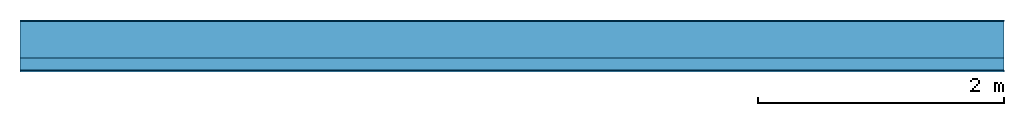
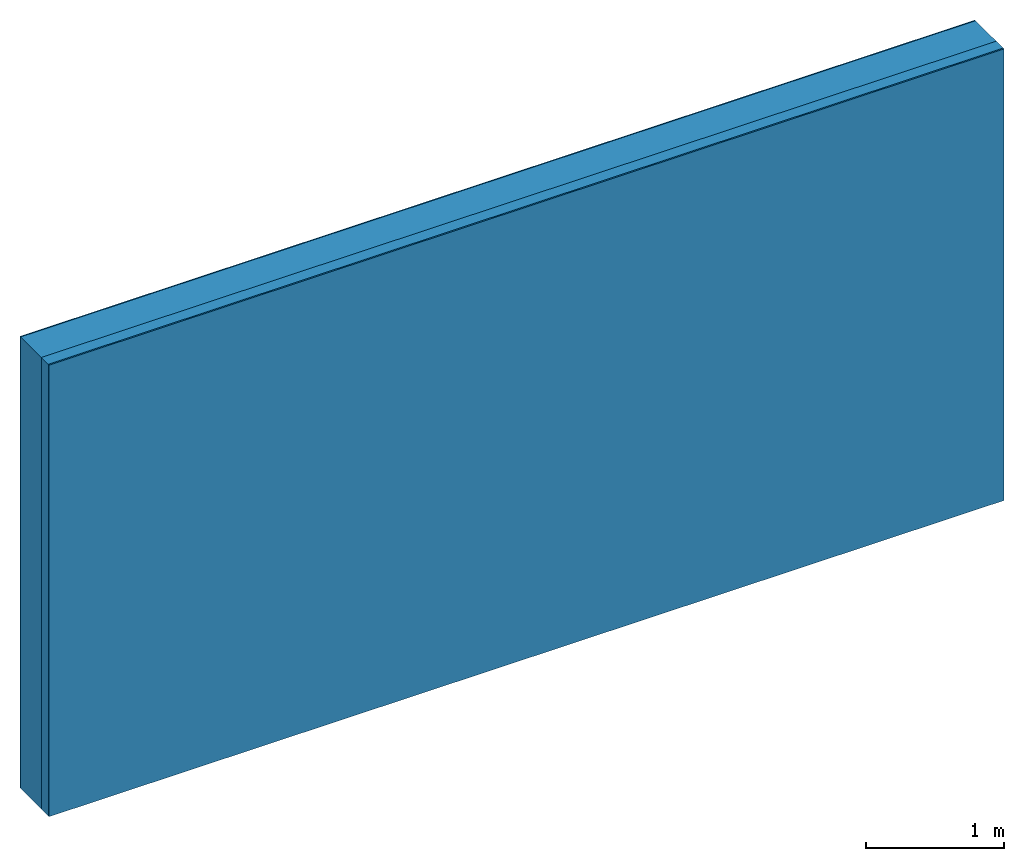
# One storey: 3 plates, 1 member, 1 element without a shape of its own.
"""IFC4 building model written with IfcOpenShell, lengths in metres."""

from ifc_helpers import new_model, si_unit, derived_unit, direction, frame, frame_2d, origin, origin_with_axes, place, context, project, spatial, rectangle, extrude, material, layer, layer_set, type_object, element, aggregate, save


model = new_model("IFC4")

# Units and contexts
plan_context = context("Plan", 3, precision=1e-05, world=origin(), true_north=direction((0.0, 1.0)))
model_context = context("Model", 3, precision=1e-05, world=origin(), true_north=direction((0.0, 1.0)))
ifc_project = project(units=[si_unit("LENGTHUNIT", "METRE"), derived_unit("SOUNDPRESSUREUNIT", [(si_unit("PRESSUREUNIT", "PASCAL", prefix="MICRO"), 0)]), si_unit("ENERGYUNIT", "JOULE", prefix="MEGA"), si_unit("MASSUNIT", "GRAM", prefix="KILO"), derived_unit("THERMALTRANSMITTANCEUNIT", [(si_unit("POWERUNIT", "WATT"), 1), (si_unit("AREAUNIT", "SQUARE_METRE"), -1), (si_unit("THERMODYNAMICTEMPERATUREUNIT", "KELVIN"), -1)]), derived_unit("AREADENSITYUNIT", [(si_unit("MASSUNIT", "GRAM", prefix="KILO"), 1), (si_unit("AREAUNIT", "SQUARE_METRE"), -1)]), derived_unit("USERDEFINED", [(si_unit("ENERGYUNIT", "JOULE", prefix="MEGA"), 1), (si_unit("AREAUNIT", "SQUARE_METRE"), -1)])], contexts=[plan_context, model_context])

# Site, building, storey
site = spatial("IfcSite", under=ifc_project)
building_placement = place(None, origin())
building = spatial("IfcBuilding", under=site, at=building_placement)
storey_placement = place(building_placement, origin())
storey = spatial("IfcBuildingStorey", under=building, at=storey_placement)

# Wall, member, plates
ifc_material_1 = material(Category="04.011")
ifc_layer_1 = layer(ifc_material_1, 0.01, Name="Surface 1")
ifc_material_2 = material(Name="Mineral wool", Category="10.008")
ifc_layer_2 = layer(ifc_material_2, 0.3, Name="outside 1st layer")
ifc_material_3 = material(Name="of the art")
ifc_layer_3 = layer(ifc_material_3, 0.0, Name="Bond")
ifc_layer_4 = layer(None, 0.1, Name="Support")
ifc_layer_5 = layer(ifc_material_3, 0.0, Name="Bond")
ifc_material_4 = material(Name="Plasterboard type A", Category="03.008")
ifc_layer_6 = layer(ifc_material_4, 0.0125, Name="1st layer")
ifc_material_5 = material(Name="joints", Category="04.017")
ifc_layer_7 = layer(ifc_material_5, 0.0, Name="Surface")
ifc_layer_set = layer_set([ifc_layer_1, ifc_layer_2, ifc_layer_3, ifc_layer_4, ifc_layer_5, ifc_layer_6, ifc_layer_7])
wall_type = type_object("IfcWallType", Name="D1028", PredefinedType="NOTDEFINED", material=ifc_layer_set)
wall_placement = place(None, frame((0.0, 0.0, 0.0), z_axis=(0.0, -1.0, 0.0), x_axis=(1.0, 0.0, 0.0)))
wall = element("IfcWall", 1, at=wall_placement, inside=storey, type_object=wall_type, material=ifc_layer_set, Name="Wall #1")
ifc_material_6 = material(Name="Solid timber panel")
member_placement = place(wall_placement, origin())
member = element("IfcMember", 2, at=member_placement, material=ifc_material_6, Name="Support", context=plan_context, shape_type="SweptSolid", body=[
    extrude(rectangle(XDim=1.0, YDim=0.1, at=frame_2d((0.5, 0.05), x_axis=(1.0, 0.0))), frame((0.0, 4.0, 0.31), z_axis=(0.0, -1.0, 0.0), x_axis=(1.0, 0.0, 0.0)), (0.0, 0.0, 1.0), 4.0),
    extrude(rectangle(XDim=1.0, YDim=0.1, at=frame_2d((0.5, 0.05), x_axis=(1.0, 0.0))), frame((1.0, 4.0, 0.31), z_axis=(0.0, -1.0, 0.0), x_axis=(1.0, 0.0, 0.0)), (0.0, 0.0, 1.0), 4.0),
    extrude(rectangle(XDim=1.0, YDim=0.1, at=frame_2d((0.5, 0.05), x_axis=(1.0, 0.0))), frame((2.0, 4.0, 0.31), z_axis=(0.0, -1.0, 0.0), x_axis=(1.0, 0.0, 0.0)), (0.0, 0.0, 1.0), 4.0),
    extrude(rectangle(XDim=1.0, YDim=0.1, at=frame_2d((0.5, 0.05), x_axis=(1.0, 0.0))), frame((3.0, 4.0, 0.31), z_axis=(0.0, -1.0, 0.0), x_axis=(1.0, 0.0, 0.0)), (0.0, 0.0, 1.0), 4.0),
    extrude(rectangle(XDim=1.0, YDim=0.1, at=frame_2d((0.5, 0.05), x_axis=(1.0, 0.0))), frame((4.0, 4.0, 0.31), z_axis=(0.0, -1.0, 0.0), x_axis=(1.0, 0.0, 0.0)), (0.0, 0.0, 1.0), 4.0),
    extrude(rectangle(XDim=1.0, YDim=0.1, at=frame_2d((0.5, 0.05), x_axis=(1.0, 0.0))), frame((5.0, 4.0, 0.31), z_axis=(0.0, -1.0, 0.0), x_axis=(1.0, 0.0, 0.0)), (0.0, 0.0, 1.0), 4.0),
    extrude(rectangle(XDim=1.0, YDim=0.1, at=frame_2d((0.5, 0.05), x_axis=(1.0, 0.0))), frame((6.0, 4.0, 0.31), z_axis=(0.0, -1.0, 0.0), x_axis=(1.0, 0.0, 0.0)), (0.0, 0.0, 1.0), 4.0),
    extrude(rectangle(XDim=1.0, YDim=0.1, at=frame_2d((0.5, 0.05), x_axis=(1.0, 0.0))), frame((7.0, 4.0, 0.31), z_axis=(0.0, -1.0, 0.0), x_axis=(1.0, 0.0, 0.0)), (0.0, 0.0, 1.0), 4.0),
])
plate_1_placement = place(wall_placement, origin())
plate_1 = element("IfcPlate", 3, at=plate_1_placement, material=ifc_material_1, Name="Surface 1", context=plan_context, shape_type="SweptSolid", body=[
    extrude(rectangle(XDim=8.0, YDim=4.0, at=frame_2d((4.0, 2.0), x_axis=(1.0, 0.0))), origin_with_axes(), (0.0, 0.0, 1.0), 0.01),
])
plate_2_placement = place(wall_placement, origin())
plate_2 = element("IfcPlate", 4, at=plate_2_placement, material=ifc_material_2, Name="outside 1st layer", context=plan_context, shape_type="SweptSolid", body=[
    extrude(rectangle(XDim=8.0, YDim=4.0, at=frame_2d((4.0, 2.0), x_axis=(1.0, 0.0))), frame((0.0, 0.0, 0.01), z_axis=(0.0, 0.0, 1.0), x_axis=(1.0, 0.0, 0.0)), (0.0, 0.0, 1.0), 0.3),
])
plate_3_placement = place(wall_placement, origin())
plate_3 = element("IfcPlate", 5, at=plate_3_placement, material=ifc_material_4, Name="1st layer", context=plan_context, shape_type="SweptSolid", body=[
    extrude(rectangle(XDim=8.0, YDim=4.0, at=frame_2d((4.0, 2.0), x_axis=(1.0, 0.0))), frame((0.0, 0.0, 0.41), z_axis=(0.0, 0.0, 1.0), x_axis=(1.0, 0.0, 0.0)), (0.0, 0.0, 1.0), 0.0125),
])
aggregate(wall, [plate_1, plate_2, member, plate_3])

save(model, "model.ifc")
